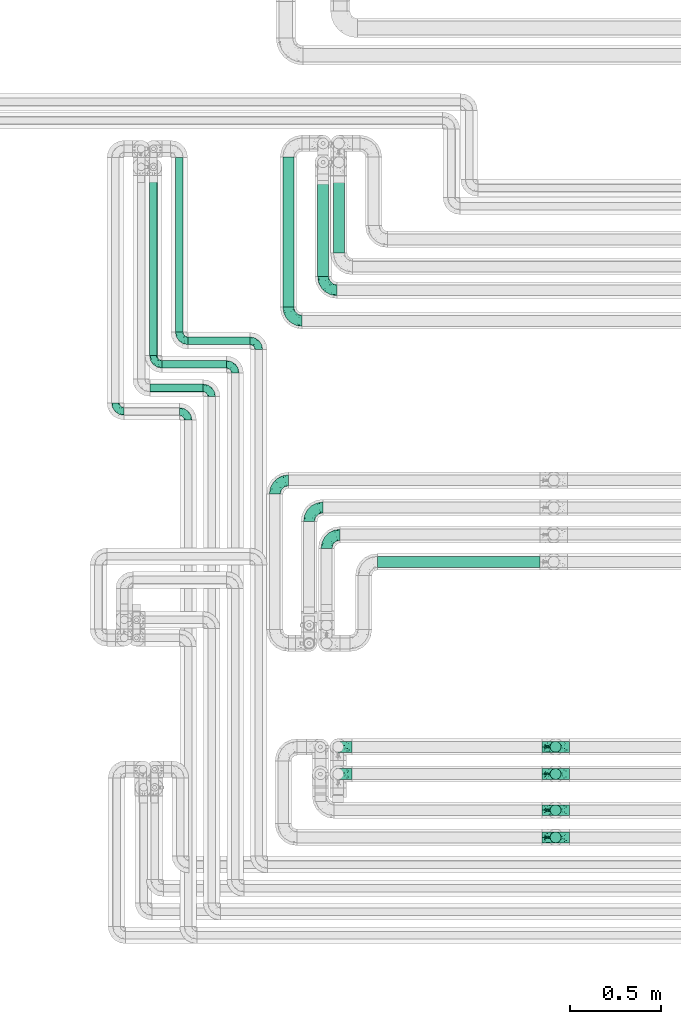
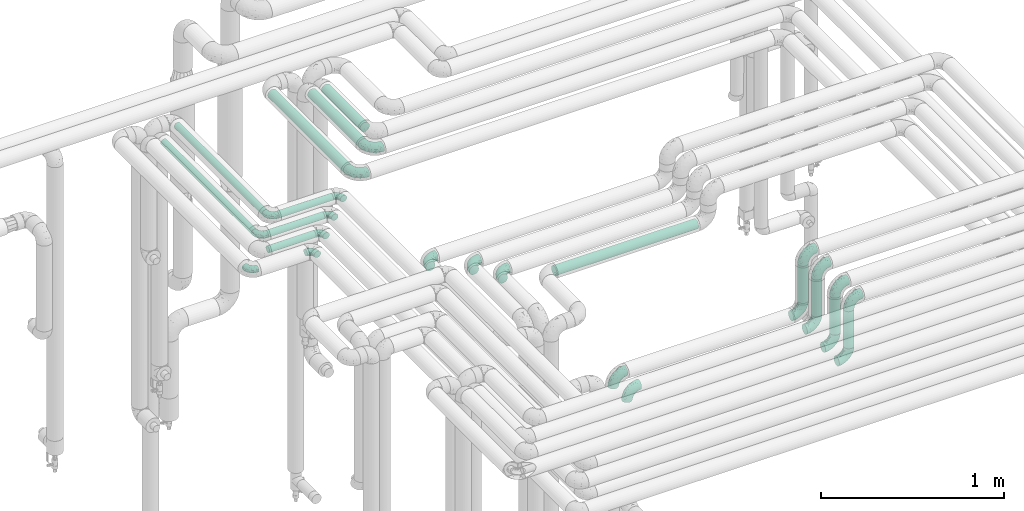
# One storey, part 633 of 824: 22 flow fittings, 13 flow segments.
"""IFC2X3 building model written with IfcOpenShell, lengths in millimetres."""

from ifc_helpers import new_model, entity, si_unit, converted_unit, derived_unit, direction, frame, origin, origin_2d_with_axis, place, context, subcontext, project, spatial, circle, extrude, faceted_brep, source, transform, mapped, material, type_object, type_shapes, element, save


model = new_model("IFC2X3")

# Units and contexts
model_context = context("Model", 3, precision=0.01, world=origin(), true_north=direction((6.12303176911189e-17, 1.0)))
body_context = subcontext(model_context, "Body", "Model", "MODEL_VIEW")
ifc_project = project(units=[si_unit("LENGTHUNIT", "METRE", prefix="MILLI"), si_unit("AREAUNIT", "SQUARE_METRE"), si_unit("VOLUMEUNIT", "CUBIC_METRE"), converted_unit("PLANEANGLEUNIT", "DEGREE", entity("IfcRatioMeasure", 0.0174532925199433), si_unit("PLANEANGLEUNIT", "RADIAN"), dimensions=[0, 0, 0, 0, 0, 0, 0]), si_unit("MASSUNIT", "GRAM", prefix="KILO"), derived_unit("MASSDENSITYUNIT", [(si_unit("MASSUNIT", "GRAM", prefix="KILO"), 1), (si_unit("LENGTHUNIT", "METRE"), -3)]), derived_unit("MOMENTOFINERTIAUNIT", [(si_unit("LENGTHUNIT", "METRE"), 4)]), si_unit("TIMEUNIT", "SECOND"), si_unit("FREQUENCYUNIT", "HERTZ"), si_unit("THERMODYNAMICTEMPERATUREUNIT", "DEGREE_CELSIUS"), derived_unit("THERMALTRANSMITTANCEUNIT", [(si_unit("MASSUNIT", "GRAM", prefix="KILO"), 1), (si_unit("THERMODYNAMICTEMPERATUREUNIT", "KELVIN"), -1), (si_unit("TIMEUNIT", "SECOND"), -3)]), derived_unit("VOLUMETRICFLOWRATEUNIT", [(si_unit("LENGTHUNIT", "METRE"), 3), (si_unit("TIMEUNIT", "SECOND"), -1)]), derived_unit("MASSFLOWRATEUNIT", [(si_unit("MASSUNIT", "GRAM", prefix="KILO"), 1), (si_unit("TIMEUNIT", "SECOND"), -1)]), derived_unit("ROTATIONALFREQUENCYUNIT", [(si_unit("TIMEUNIT", "SECOND"), -1)]), si_unit("ELECTRICCURRENTUNIT", "AMPERE"), si_unit("ELECTRICVOLTAGEUNIT", "VOLT"), si_unit("POWERUNIT", "WATT"), si_unit("FORCEUNIT", "NEWTON", prefix="KILO"), si_unit("ILLUMINANCEUNIT", "LUX"), si_unit("LUMINOUSFLUXUNIT", "LUMEN"), si_unit("LUMINOUSINTENSITYUNIT", "CANDELA"), derived_unit("USERDEFINED", [(si_unit("MASSUNIT", "GRAM", prefix="KILO"), -1), (si_unit("LENGTHUNIT", "METRE"), -2), (si_unit("TIMEUNIT", "SECOND"), 3), (si_unit("LUMINOUSFLUXUNIT", "LUMEN"), 1)]), derived_unit("LINEARVELOCITYUNIT", [(si_unit("LENGTHUNIT", "METRE"), 1), (si_unit("TIMEUNIT", "SECOND"), -1)]), si_unit("PRESSUREUNIT", "PASCAL"), derived_unit("USERDEFINED", [(si_unit("LENGTHUNIT", "METRE"), -2), (si_unit("MASSUNIT", "GRAM", prefix="KILO"), 1), (si_unit("TIMEUNIT", "SECOND"), -2)]), derived_unit("LINEARFORCEUNIT", [(si_unit("MASSUNIT", "GRAM", prefix="KILO"), 1), (si_unit("LENGTHUNIT", "METRE"), 1), (si_unit("TIMEUNIT", "SECOND"), -2), (si_unit("LENGTHUNIT", "METRE"), -1)]), derived_unit("PLANARFORCEUNIT", [(si_unit("MASSUNIT", "GRAM", prefix="KILO"), 1), (si_unit("LENGTHUNIT", "METRE"), 1), (si_unit("TIMEUNIT", "SECOND"), -2), (si_unit("LENGTHUNIT", "METRE"), -2)])], contexts=[model_context])

# Site, building, storey
site_placement = place(None, origin())
site = spatial("IfcSite", under=ifc_project, at=site_placement, CompositionType="ELEMENT")
building_placement = place(site_placement, origin())
building = spatial("IfcBuilding", under=site, at=building_placement, CompositionType="ELEMENT")
storey_placement = place(building_placement, frame((0.0, 0.0, 28200.0)))
storey = spatial("IfcBuildingStorey", under=building, at=storey_placement, CompositionType="ELEMENT", Elevation=28200.0)

# Flow segments
pipe_segment_type = type_object("IfcPipeSegmentType", PredefinedType="NOTDEFINED")
flow_segment_1_placement = place(storey_placement, frame((30915.6, 17358.46, 2977.25)))
element("IfcFlowSegment", 1, at=flow_segment_1_placement, inside=storey, type_object=pipe_segment_type, context=body_context, shape_type="SweptSolid", body=[
    extrude(circle(Radius=21.15, at=origin_2d_with_axis()), frame((0.0, 22.75, 22.75), z_axis=(1.0, 0.0, 0.0), x_axis=(0.0, -1.0, 0.0)), (0.0, 0.0, 1.0), 342.918088784113),
])
flow_segment_2_placement = place(storey_placement, frame((31438.07, 17567.2, 2968.4)))
element("IfcFlowSegment", 2, at=flow_segment_2_placement, inside=storey, type_object=pipe_segment_type, context=body_context, shape_type="SweptSolid", body=[
    extrude(circle(Radius=30.0, at=origin_2d_with_axis()), frame((31.6, 0.0, 31.6), z_axis=(0.0, 1.0, 0.0), x_axis=(1.0, 0.0, 0.0)), (0.0, 0.0, 1.0), 828.00000018509),
])
flow_segment_3_placement = place(storey_placement, frame((30773.07, 17228.46, 2977.25)))
element("IfcFlowSegment", 3, at=flow_segment_3_placement, inside=storey, type_object=pipe_segment_type, context=body_context, shape_type="SweptSolid", body=[
    extrude(circle(Radius=21.15, at=origin_2d_with_axis()), frame((0.0, 22.75, 22.75), z_axis=(1.0, 0.0, 0.0), x_axis=(0.0, -1.0, 0.0)), (0.0, 0.0, 1.0), 355.449929999979),
])
flow_segment_4_placement = place(storey_placement, frame((30705.05, 17098.46, 2977.25)))
element("IfcFlowSegment", 4, at=flow_segment_4_placement, inside=storey, type_object=pipe_segment_type, context=body_context, shape_type="SweptSolid", body=[
    extrude(circle(Radius=21.15, at=origin_2d_with_axis()), frame((0.0, 22.75, 22.75), z_axis=(1.0, 0.0, 0.0), x_axis=(0.0, -1.0, 0.0)), (0.0, 0.0, 1.0), 293.47319999997),
])
flow_segment_5_placement = place(storey_placement, frame((30844.86, 17429.2, 2977.25)))
element("IfcFlowSegment", 5, at=flow_segment_5_placement, inside=storey, type_object=pipe_segment_type, context=body_context, shape_type="SweptSolid", body=[
    extrude(circle(Radius=21.15, at=origin_2d_with_axis()), frame((22.75, 0.0, 22.75), z_axis=(0.0, 1.0, 0.0), x_axis=(1.0, 0.0, 0.0)), (0.0, 0.0, 1.0), 963.999999953802),
])
flow_segment_6_placement = place(storey_placement, frame((30702.33, 17299.2, 2977.25)))
element("IfcFlowSegment", 6, at=flow_segment_6_placement, inside=storey, type_object=pipe_segment_type, context=body_context, shape_type="SweptSolid", body=[
    extrude(circle(Radius=21.15, at=origin_2d_with_axis()), frame((22.75, 0.0, 22.75), z_axis=(0.0, 1.0, 0.0), x_axis=(-1.0, 0.0, 0.0)), (0.0, 0.0, 1.0), 993.999999999995),
])
flow_segment_7_placement = place(storey_placement, frame((31630.07, 17736.2, 2968.4)))
element("IfcFlowSegment", 7, at=flow_segment_7_placement, inside=storey, type_object=pipe_segment_type, context=body_context, shape_type="SweptSolid", body=[
    extrude(circle(Radius=30.0, at=origin_2d_with_axis()), frame((31.6, 0.0, 31.6), z_axis=(0.0, 1.0, 0.0), x_axis=(1.0, 0.0, 0.0)), (0.0, 0.0, 1.0), 554.746270361103),
])
flow_segment_8_placement = place(storey_placement, frame((31717.07, 17867.2, 2968.4)))
element("IfcFlowSegment", 8, at=flow_segment_8_placement, inside=storey, type_object=pipe_segment_type, context=body_context, shape_type="SweptSolid", body=[
    extrude(circle(Radius=30.0, at=origin_2d_with_axis()), frame((31.6, 0.0, 31.6), z_axis=(0.0, 1.0, 0.0), x_axis=(1.0, 0.0, 0.0)), (0.0, 0.0, 1.0), 423.74627954619),
])
for number, where in (
    (9, (32913.44, 15108.41, 3076.0)),
    (10, (32913.44, 14958.41, 3076.0)),
    (11, (32913.44, 14758.41, 3076.0)),
):
    element("IfcFlowSegment", number, at=place(storey_placement, frame(where)), inside=storey, type_object=pipe_segment_type, context=body_context, shape_type="SweptSolid", body=[
        extrude(circle(Radius=30.0, at=origin_2d_with_axis()), frame((31.6, 31.6, 0.0)), (0.0, 0.0, 1.0), 248.000000000013),
    ])
flow_segment_9_placement = place(storey_placement, frame((32913.44, 14608.41, 3076.0)))
element("IfcFlowSegment", 12, at=flow_segment_9_placement, inside=storey, type_object=pipe_segment_type, context=body_context, shape_type="SweptSolid", body=[
    extrude(circle(Radius=30.0, at=origin_2d_with_axis()), frame((31.6, 31.6, 0.0)), (0.0, 0.0, 1.0), 248.000000000022),
])
flow_segment_10_placement = place(storey_placement, frame((31961.25, 16129.61, 2968.4)))
element("IfcFlowSegment", 13, at=flow_segment_10_placement, inside=storey, type_object=pipe_segment_type, context=body_context, shape_type="SweptSolid", body=[
    extrude(circle(Radius=30.0, at=origin_2d_with_axis()), frame((0.0, 31.6, 31.6), z_axis=(1.0, 0.0, 0.0), x_axis=(0.0, 1.0, 0.0)), (0.0, 0.0, 1.0), 897.780008999999),
])

# Flow fittings
ifc_material = material()
pipe_fitting_type_1 = type_object("IfcPipeFittingType", PredefinedType="NOTDEFINED", material=ifc_material)
shared_shape_1 = source(origin(), body_context, "Body", "Brep", [
    faceted_brep([(-48.0, 10.6, -18.36), (-48.0, 5.49, -20.48), (-48.0, 0.0, -21.2), (-48.0, -5.49, -20.48), (-48.0, -10.6, -18.36), (-48.0, -14.99, -14.99), (-48.0, -18.36, -10.6), (-48.0, -20.48, -5.49), (-48.0, -21.2, 0.0), (-48.0, -20.48, 5.49), (-48.0, -18.36, 10.6), (-48.0, -14.99, 14.99), (-48.0, -10.6, 18.36), (-48.0, -5.49, 20.48), (-48.0, 0.0, 21.2), (-48.0, 5.49, 20.48), (-48.0, 10.6, 18.36), (-48.0, 14.99, 14.99), (-48.0, 18.36, 10.6), (-48.0, 20.48, 5.49), (-48.0, 21.2, 0.0), (-48.0, 20.48, -5.49), (-48.0, 18.36, -10.6), (-48.0, 14.99, -14.99), (0.0, 48.0, -21.2), (-5.49, 48.0, -20.48), (-10.6, 48.0, -18.36), (-14.99, 48.0, -14.99), (-18.36, 48.0, -10.6), (-20.48, 48.0, -5.49), (-21.2, 48.0, 0.0), (-20.48, 48.0, 5.49), (-18.36, 48.0, 10.6), (-14.99, 48.0, 14.99), (-10.6, 48.0, 18.36), (-5.49, 48.0, 20.48), (0.0, 48.0, 21.2), (5.49, 48.0, 20.48), (10.6, 48.0, 18.36), (14.99, 48.0, 14.99), (18.36, 48.0, 10.6), (20.48, 48.0, 5.49), (21.2, 48.0, 0.0), (20.48, 48.0, -5.49), (18.36, 48.0, -10.6), (14.99, 48.0, -14.99), (10.6, 48.0, -18.36), (5.49, 48.0, -20.48), (-35.25, -16.22, 12.01), (-34.76, -18.57, 0.0), (-20.87, -12.37, 10.9), (-31.49, -11.78, 15.9), (-37.0, -2.58, 20.86), (-33.89, 3.62, 21.15), (-31.81, -18.14, 6.76), (-5.78, 5.78, 17.67), (-19.42, -4.1, 17.86), (-9.6, -3.39, 13.73), (-35.44, -7.73, 19.13), (11.78, 31.49, 15.9), (-5.93, -5.46, 6.95), (-18.45, -13.78, 5.46), (-10.29, -8.43, 0.0), (-24.6, 0.55, 20.62), (-37.28, 17.94, 13.81), (-33.38, 22.85, 9.59), (-41.46, 20.06, 8.75), (-29.51, 20.45, 15.16), (-15.04, 10.79, 21.13), (-7.08, 16.98, 20.93), (-8.39, 23.51, 21.15), (-40.86, 13.03, 17.26), (-8.05, 41.26, 19.83), (-3.21, 35.97, 21.14), (8.53, 19.66, 14.74), (4.1, 19.42, 17.86), (-37.72, 22.66, 4.78), (-37.07, 8.58, 19.98), (-13.0, 5.43, 19.97), (-3.78, 13.93, 19.7), (3.02, 8.69, 13.43), (-2.27, -0.05, 10.65), (6.22, 6.99, 7.09), (-22.25, 34.6, 9.45), (18.14, 31.81, 6.76), (16.22, 35.25, 12.01), (12.37, 20.87, 10.9), (7.73, 35.44, 19.13), (-21.52, -15.93, 0.0), (2.58, 37.0, 20.86), (18.57, 34.76, 0.0), (13.78, 18.45, 5.46), (15.93, 21.52, 0.0), (-20.03, -8.54, 14.9), (-28.6, 28.6, 5.16), (-24.79, 34.6, 0.0), (-34.6, 24.79, 0.0), (-22.81, 37.41, 4.68), (-23.36, 26.33, 14.79), (-13.68, 37.05, 17.49), (-17.72, 38.12, 13.73), (-26.25, 27.3, 11.24), (-9.71, 32.34, 20.14), (-17.26, 25.6, 18.71), (-26.33, 9.99, 20.77), (-24.06, 6.05, 21.2), (-25.02, 15.46, 19.56), (-24.3, 20.72, 17.57), (-31.95, 15.23, 17.8), (-13.53, 24.7, 20.21), (-17.6, 17.6, 20.6), (-0.55, 24.6, 20.62), (-11.41, -7.48, 10.43), (0.93, -0.93, 0.0), (8.43, 10.29, 0.0), (-11.41, -7.48, -10.43), (-20.1, -8.84, -14.66), (-9.6, -3.39, -13.73), (7.73, 35.44, -19.13), (4.1, 19.42, -17.86), (-0.55, 24.6, -20.62), (-38.12, 17.72, -13.73), (-37.05, 13.68, -17.49), (-32.34, 9.71, -20.14), (-41.26, 8.05, -19.83), (-37.41, 22.81, -4.68), (-23.51, 8.39, -21.15), (-35.97, 3.21, -21.14), (-28.6, 28.6, -5.16), (-31.81, -18.14, -6.76), (-18.45, -13.78, -5.46), (-25.6, 17.26, -18.71), (-19.42, -4.1, -17.86), (-17.94, 37.28, -13.81), (-22.85, 33.38, -9.59), (-20.06, 41.46, -8.75), (-31.49, -11.78, -15.9), (-35.25, -16.22, -12.01), (8.53, 19.66, -14.74), (11.78, 31.49, -15.9), (-9.99, 26.33, -20.77), (-6.05, 24.06, -21.2), (-10.79, 15.04, -21.13), (-37.0, -2.58, -20.86), (-16.98, 7.08, -20.93), (-5.43, 13.0, -19.97), (-13.93, 3.78, -19.7), (-20.87, -12.37, -10.9), (-26.33, 23.36, -14.79), (-22.66, 37.72, -4.78), (13.78, 18.45, -5.46), (18.14, 31.81, -6.76), (-15.46, 25.02, -19.56), (-20.72, 24.3, -17.57), (16.22, 35.25, -12.01), (-13.03, 40.86, -17.26), (-8.58, 37.07, -19.98), (2.58, 37.0, -20.86), (-3.62, 33.89, -21.15), (-34.6, 22.25, -9.45), (6.22, 6.99, -7.09), (-20.45, 29.51, -15.16), (-35.44, -7.73, -19.13), (12.37, 20.87, -10.9), (-27.3, 26.25, -11.24), (-15.23, 31.95, -17.8), (-24.7, 13.53, -20.21), (-24.6, 0.55, -20.62), (-5.78, 5.78, -17.67), (-17.6, 17.6, -20.6), (3.02, 8.69, -13.43), (-5.93, -5.46, -6.95), (-2.27, -0.05, -10.65)], [[[0, 1, 2, 3, 4, 5, 6, 7, 8, 9, 10, 11, 12, 13, 14, 15, 16, 17, 18, 19, 20, 21, 22, 23]], [[24, 25, 26, 27, 28, 29, 30, 31, 32, 33, 34, 35, 36, 37, 38, 39, 40, 41, 42, 43, 44, 45, 46, 47]], [[10, 48, 11]], [[9, 8, 49]], [[48, 50, 51]], [[14, 52, 53]], [[10, 54, 48]], [[9, 54, 10]], [[55, 56, 57]], [[51, 12, 11]], [[51, 58, 12]], [[59, 39, 38]], [[60, 61, 62]], [[58, 56, 63]], [[64, 65, 66]], [[67, 65, 64]], [[68, 69, 70]], [[16, 71, 17]], [[13, 52, 14]], [[35, 72, 73]], [[14, 53, 15]], [[17, 64, 18]], [[74, 59, 75]], [[20, 19, 76]], [[66, 19, 18]], [[77, 15, 53]], [[15, 77, 16]], [[69, 78, 79]], [[80, 81, 82]], [[32, 31, 83]], [[84, 85, 86]], [[59, 87, 75]], [[61, 54, 88]], [[36, 89, 37]], [[84, 41, 40]], [[36, 35, 73]], [[90, 41, 84]], [[40, 39, 85]], [[12, 58, 13]], [[85, 84, 40]], [[91, 84, 86]], [[84, 92, 90]], [[87, 38, 37]], [[93, 56, 51]], [[65, 94, 76]], [[94, 95, 96]], [[84, 91, 92]], [[95, 97, 30]], [[98, 99, 100]], [[76, 94, 96]], [[101, 98, 83]], [[100, 99, 33]], [[102, 70, 73]], [[103, 102, 99]], [[94, 97, 95]], [[72, 99, 102]], [[72, 35, 34]], [[34, 33, 99]], [[9, 49, 54]], [[87, 59, 38]], [[104, 105, 68]], [[106, 103, 107]], [[106, 77, 104]], [[71, 64, 17]], [[108, 107, 67]], [[33, 32, 100]], [[109, 103, 110]], [[102, 109, 70]], [[89, 73, 111]], [[50, 48, 54]], [[51, 11, 48]], [[56, 58, 51]], [[88, 54, 49]], [[52, 58, 63]], [[50, 112, 93]], [[56, 55, 78]], [[39, 59, 85]], [[86, 85, 59]], [[89, 87, 37]], [[42, 41, 90]], [[111, 79, 75]], [[111, 75, 87]], [[75, 55, 80]], [[104, 77, 53]], [[71, 77, 108]], [[32, 83, 100]], [[98, 100, 83]], [[99, 98, 103]], [[106, 107, 108]], [[68, 70, 110]], [[111, 73, 70]], [[68, 110, 104]], [[68, 63, 78]], [[57, 93, 112]], [[80, 55, 57]], [[61, 50, 54]], [[80, 82, 86]], [[81, 57, 112]], [[74, 86, 59]], [[60, 113, 82]], [[82, 114, 91]], [[101, 94, 65]], [[97, 94, 83]], [[73, 89, 36]], [[87, 89, 111]], [[58, 52, 13]], [[53, 52, 63]], [[104, 53, 105]], [[106, 104, 110]], [[20, 76, 96]], [[76, 19, 66]], [[103, 106, 110]], [[77, 106, 108]], [[103, 98, 107]], [[67, 107, 98]], [[67, 98, 101]], [[108, 67, 64]], [[53, 63, 105]], [[63, 68, 105]], [[83, 31, 97]], [[30, 97, 31]], [[62, 113, 60]], [[112, 61, 60]], [[61, 88, 62]], [[86, 82, 91]], [[56, 78, 63]], [[114, 82, 113]], [[114, 92, 91]], [[79, 78, 55]], [[75, 79, 55]], [[69, 79, 111]], [[70, 69, 111]], [[78, 69, 68]], [[77, 71, 16]], [[64, 71, 108]], [[64, 66, 18]], [[76, 66, 65]], [[99, 72, 34]], [[73, 72, 102]], [[94, 101, 83]], [[67, 101, 65]], [[75, 80, 74]], [[80, 86, 74]], [[70, 109, 110]], [[102, 103, 109]], [[50, 93, 51]], [[57, 56, 93]], [[61, 112, 50]], [[81, 112, 60]], [[82, 81, 60]], [[80, 57, 81]], [[115, 116, 117]], [[118, 119, 120]], [[121, 122, 23]], [[123, 124, 122]], [[96, 125, 20]], [[123, 126, 127]], [[128, 96, 95]], [[129, 130, 88]], [[123, 122, 131]], [[116, 132, 117]], [[133, 134, 135]], [[0, 124, 1]], [[5, 136, 137]], [[138, 119, 139]], [[129, 88, 49]], [[140, 141, 142]], [[6, 5, 137]], [[46, 118, 47]], [[143, 3, 2]], [[144, 145, 146]], [[6, 129, 7]], [[129, 137, 147]], [[127, 2, 1]], [[148, 122, 121]], [[128, 125, 96]], [[134, 128, 149]], [[95, 149, 128]], [[150, 151, 92]], [[30, 29, 149]], [[152, 131, 153]], [[27, 133, 28]], [[154, 45, 44]], [[136, 5, 4]], [[27, 26, 155]], [[156, 26, 25]], [[24, 157, 158]], [[24, 47, 157]], [[22, 21, 159]], [[160, 150, 114]], [[134, 133, 161]], [[142, 144, 126]], [[46, 139, 118]], [[162, 136, 4]], [[156, 25, 158]], [[1, 124, 127]], [[115, 147, 116]], [[45, 154, 139]], [[139, 46, 45]], [[154, 163, 139]], [[162, 4, 3]], [[42, 90, 43]], [[130, 129, 147]], [[49, 7, 129]], [[43, 151, 44]], [[0, 23, 122]], [[24, 158, 25]], [[136, 162, 132]], [[135, 29, 28]], [[43, 90, 151]], [[164, 148, 159]], [[152, 156, 140]], [[155, 133, 27]], [[165, 153, 161]], [[23, 22, 121]], [[123, 131, 166]], [[123, 166, 126]], [[143, 127, 167]], [[147, 137, 136]], [[8, 7, 49]], [[129, 6, 137]], [[143, 162, 3]], [[167, 146, 132]], [[167, 132, 162]], [[132, 168, 117]], [[44, 151, 154]], [[92, 151, 90]], [[163, 154, 151]], [[119, 118, 139]], [[157, 118, 120]], [[138, 139, 163]], [[119, 168, 145]], [[140, 156, 158]], [[155, 156, 165]], [[22, 159, 121]], [[148, 121, 159]], [[122, 148, 131]], [[152, 153, 165]], [[142, 126, 169]], [[167, 127, 126]], [[142, 169, 140]], [[142, 120, 145]], [[168, 170, 117]], [[160, 171, 172]], [[115, 172, 171]], [[171, 62, 130]], [[119, 170, 168]], [[170, 163, 160]], [[150, 163, 151]], [[113, 171, 160]], [[164, 128, 134]], [[125, 128, 159]], [[127, 143, 2]], [[162, 143, 167]], [[118, 157, 47]], [[158, 157, 120]], [[140, 158, 141]], [[152, 140, 169]], [[30, 149, 95]], [[149, 29, 135]], [[131, 152, 169]], [[156, 152, 165]], [[131, 148, 153]], [[161, 153, 148]], [[161, 148, 164]], [[165, 161, 133]], [[158, 120, 141]], [[120, 142, 141]], [[159, 21, 125]], [[20, 125, 21]], [[115, 130, 147]], [[114, 113, 160]], [[62, 171, 113]], [[62, 88, 130]], [[160, 163, 150]], [[150, 92, 114]], [[119, 145, 120]], [[146, 145, 168]], [[132, 146, 168]], [[144, 146, 167]], [[126, 144, 167]], [[145, 144, 142]], [[156, 155, 26]], [[133, 155, 165]], [[133, 135, 28]], [[149, 135, 134]], [[122, 124, 0]], [[127, 124, 123]], [[128, 164, 159]], [[161, 164, 134]], [[163, 170, 138]], [[170, 119, 138]], [[131, 169, 166]], [[126, 166, 169]], [[147, 136, 116]], [[132, 116, 136]], [[172, 115, 117]], [[130, 115, 171]], [[117, 170, 172]], [[160, 172, 170]]]),
])
type_shapes(pipe_fitting_type_1, [shared_shape_1])
for number, where, z_axis, x_axis in (
    (14, (30867.6, 17381.2, 3000.0), (0.0, 0.0, 1.0), (0.0, -1.0, 0.0)),
    (15, (31176.52, 17251.2, 3000.0), (0.0, 0.0, 1.0), (0.0, 1.0, 0.0)),
    (16, (31046.52, 17121.2, 3000.0), (0.0, 0.0, 1.0), (0.0, 1.0, 0.0)),
    (17, (30515.05, 16991.2, 3000.0), (0.0, 0.0, 1.0), (0.0, -1.0, 0.0)),
    (18, (30916.52, 16991.2, 3000.0), (0.0, 0.0, 1.0), (0.0, 1.0, 0.0)),
    (19, (30725.07, 17251.2, 3000.0), (0.0, 0.0, 1.0), (0.0, -1.0, 0.0)),
    (20, (31306.52, 17381.2, 3000.0), (0.0, 0.0, 1.0), (0.0, 1.0, 0.0)),
):
    element("IfcFlowFitting", number, at=place(storey_placement, frame(where, z_axis=z_axis, x_axis=x_axis)), inside=storey, type_object=pipe_fitting_type_1, material=ifc_material, context=body_context, shape_type="MappedRepresentation", body=[
        mapped(shared_shape_1, transform((0.0, 0.0, 0.0), scale=1.0)),
    ])
pipe_fitting_type_2 = type_object("IfcPipeFittingType", PredefinedType="NOTDEFINED", material=ifc_material)
shared_shape_2 = source(origin(), body_context, "Body", "Brep", [
    faceted_brep([(-76.0, 15.07, -26.11), (-76.0, 7.8, -29.12), (-76.0, 0.0, -30.15), (-76.0, -7.8, -29.12), (-76.0, -15.08, -26.11), (-76.0, -21.32, -21.32), (-76.0, -26.11, -15.08), (-76.0, -29.12, -7.8), (-76.0, -30.15, 0.0), (-76.0, -29.12, 7.8), (-76.0, -26.11, 15.07), (-76.0, -21.32, 21.32), (-76.0, -15.08, 26.11), (-76.0, -7.8, 29.12), (-76.0, 0.0, 30.15), (-76.0, 7.8, 29.12), (-76.0, 15.07, 26.11), (-76.0, 21.32, 21.32), (-76.0, 26.11, 15.07), (-76.0, 29.12, 7.8), (-76.0, 30.15, 0.0), (-76.0, 29.12, -7.8), (-76.0, 26.11, -15.08), (-76.0, 21.32, -21.32), (0.0, 76.0, -30.15), (-7.8, 76.0, -29.12), (-15.07, 76.0, -26.11), (-21.32, 76.0, -21.32), (-26.11, 76.0, -15.08), (-29.12, 76.0, -7.8), (-30.15, 76.0, 0.0), (-29.12, 76.0, 7.8), (-26.11, 76.0, 15.07), (-21.32, 76.0, 21.32), (-15.07, 76.0, 26.11), (-7.8, 76.0, 29.12), (0.0, 76.0, 30.15), (7.8, 76.0, 29.12), (15.08, 76.0, 26.11), (21.32, 76.0, 21.32), (26.11, 76.0, 15.07), (29.12, 76.0, 7.8), (30.15, 76.0, 0.0), (29.12, 76.0, -7.8), (26.11, 76.0, -15.08), (21.32, 76.0, -21.32), (15.08, 76.0, -26.11), (7.8, 76.0, -29.12), (10.79, 31.43, 21.07), (4.32, 31.7, 25.72), (1.65, 15.19, 19.92), (-61.17, -27.8, 0.0), (-51.1, -25.49, 9.84), (-56.14, -10.61, 27.27), (-31.7, -4.32, 25.72), (-39.75, 1.72, 29.41), (-43.2, -24.95, 0.0), (-1.86, 1.86, 0.0), (4.49, 7.65, 5.78), (-7.82, -4.61, 5.83), (-56.21, -22.79, 17.21), (-58.98, -3.38, 29.7), (-53.96, 5.6, 30.07), (-10.86, 10.86, 25.48), (-17.2, -2.6, 20.44), (-49.15, -16.01, 22.7), (-22.18, -14.24, 7.99), (-28.4, -17.42, 0.0), (-13.61, -9.88, 0.0), (-39.0, 23.48, 27.76), (-58.76, 12.54, 28.36), (-41.61, 15.41, 29.48), (16.01, 49.15, 22.7), (-58.55, 25.93, 19.53), (-51.53, 33.5, 13.51), (-64.92, 28.76, 12.4), (-7.48, 23.14, 28.25), (-1.72, 39.75, 29.41), (-12.04, 27.88, 29.88), (-63.91, 18.81, 24.52), (-11.63, 65.16, 28.18), (-4.97, 57.02, 30.05), (9.88, 13.61, 0.0), (-62.5, 31.74, 5.02), (-45.17, 30.98, 21.2), (-21.78, 9.76, 28.58), (10.61, 56.14, 27.27), (-32.09, 54.42, 13.26), (22.79, 56.21, 17.21), (15.38, 31.17, 15.63), (25.49, 51.1, 9.84), (21.84, 36.35, 5.92), (24.95, 43.2, 0.0), (3.38, 58.98, 29.7), (-31.17, -15.38, 15.63), (-39.39, 41.78, 15.45), (-34.56, 41.13, 20.79), (-39.81, -23.25, 5.49), (27.8, 61.17, 0.0), (-31.74, 62.5, 5.02), (-53.07, 36.29, 0.0), (-42.95, 42.95, 7.29), (-36.29, 53.07, 0.0), (-19.83, 58.51, 24.79), (-25.48, 60.2, 19.41), (-14.53, 50.96, 28.57), (-13.31, 37.09, 30.07), (-26.16, 40.06, 26.4), (-32.43, -10.35, 21.9), (17.42, 28.4, 0.0), (14.24, 22.18, 7.99), (-38.67, 9.72, 30.15), (-24.66, 17.36, 30.09), (-37.08, 31.49, 24.99), (-49.27, 22.83, 25.24), (-20.8, 38.81, 28.63), (-27.58, 27.58, 29.2), (-36.07, -20.23, 10.71), (-15.19, -6.16, 14.9), (6.6, 15.4, 14.49), (-2.51, 2.51, 11.35), (-65.16, 11.63, -28.18), (-49.15, -16.01, -22.7), (-57.02, 4.97, -30.05), (-25.93, 58.55, -19.53), (-33.5, 51.53, -13.51), (-28.76, 64.92, -12.4), (-60.2, 25.48, -19.41), (-58.51, 19.83, -24.79), (4.61, 7.82, -5.83), (-7.65, -4.49, -5.78), (-2.51, 2.51, -11.35), (-62.5, 31.74, -5.02), (-50.96, 14.53, -28.57), (-37.09, 13.31, -30.07), (-42.95, 42.95, -7.29), (25.49, 51.1, -9.84), (22.79, 56.21, -17.21), (-40.06, 26.16, -26.4), (3.38, 58.98, -29.7), (-5.6, 53.96, -30.07), (-27.88, 12.04, -29.88), (-9.76, 21.78, -28.58), (-23.14, 7.48, -28.25), (-51.1, -25.49, -9.84), (15.38, 31.17, -15.63), (16.01, 49.15, -22.7), (-23.48, 39.0, -27.76), (-12.54, 58.76, -28.36), (-15.41, 41.61, -29.48), (-56.21, -22.79, -17.21), (-9.72, 38.67, -30.15), (-17.36, 24.66, -30.09), (-22.18, -14.24, -7.99), (-41.13, 34.56, -20.79), (-31.74, 62.5, -5.02), (-58.98, -3.38, -29.7), (-31.17, -15.38, -15.63), (-56.14, -10.61, -27.27), (14.24, 22.18, -7.99), (23.25, 39.81, -5.49), (-31.49, 37.08, -24.99), (-15.19, -6.16, -14.9), (1.65, 15.19, -19.92), (-18.81, 63.91, -24.52), (-32.59, -11.62, -20.84), (-31.7, -4.32, -25.72), (-17.2, -2.6, -20.44), (-39.75, 1.72, -29.41), (-54.42, 32.09, -13.26), (-30.98, 45.17, -21.2), (10.61, 56.14, -27.27), (10.23, 31.31, -21.52), (4.32, 31.7, -25.72), (-41.78, 39.39, -15.45), (-1.72, 39.75, -29.41), (-36.35, -21.84, -5.92), (-22.83, 49.27, -25.24), (-38.81, 20.8, -28.63), (-27.58, 27.58, -29.2), (-10.86, 10.86, -25.48), (20.23, 36.07, -10.71), (6.6, 15.4, -14.49)], [[[0, 1, 2, 3, 4, 5, 6, 7, 8, 9, 10, 11, 12, 13, 14, 15, 16, 17, 18, 19, 20, 21, 22, 23]], [[24, 25, 26, 27, 28, 29, 30, 31, 32, 33, 34, 35, 36, 37, 38, 39, 40, 41, 42, 43, 44, 45, 46, 47]], [[48, 49, 50]], [[51, 52, 9]], [[53, 54, 55]], [[9, 52, 10]], [[56, 52, 51]], [[57, 58, 59]], [[11, 10, 60]], [[14, 61, 62]], [[63, 54, 64]], [[65, 12, 11]], [[65, 53, 12]], [[66, 67, 68]], [[69, 70, 71]], [[72, 39, 38]], [[73, 74, 75]], [[15, 70, 16]], [[76, 77, 78]], [[16, 79, 17]], [[13, 61, 14]], [[35, 80, 81]], [[14, 62, 15]], [[17, 73, 18]], [[57, 82, 58]], [[20, 19, 83]], [[75, 19, 18]], [[70, 15, 62]], [[73, 84, 74]], [[78, 85, 76]], [[38, 86, 72]], [[32, 31, 87]], [[88, 89, 90]], [[91, 92, 90]], [[72, 86, 49]], [[36, 93, 37]], [[75, 83, 19]], [[36, 35, 81]], [[60, 94, 65]], [[40, 90, 41]], [[95, 96, 87]], [[88, 90, 40]], [[66, 97, 67]], [[90, 98, 41]], [[40, 39, 88]], [[99, 31, 30]], [[20, 83, 100]], [[101, 102, 100]], [[52, 60, 10]], [[102, 99, 30]], [[96, 103, 104]], [[83, 101, 100]], [[12, 53, 13]], [[104, 103, 33]], [[105, 106, 81]], [[107, 105, 103]], [[64, 54, 108]], [[80, 103, 105]], [[80, 35, 34]], [[34, 33, 103]], [[86, 38, 37]], [[109, 110, 82]], [[71, 111, 112]], [[69, 107, 113]], [[79, 73, 17]], [[114, 113, 84]], [[33, 32, 104]], [[115, 107, 116]], [[105, 115, 106]], [[93, 81, 77]], [[54, 53, 65]], [[61, 53, 55]], [[108, 94, 64]], [[54, 63, 85]], [[93, 86, 37]], [[77, 76, 49]], [[77, 49, 86]], [[49, 63, 50]], [[60, 52, 117]], [[65, 11, 60]], [[39, 72, 88]], [[89, 88, 72]], [[71, 70, 62]], [[79, 70, 114]], [[103, 96, 107]], [[69, 113, 114]], [[112, 106, 116]], [[77, 81, 106]], [[112, 116, 71]], [[112, 55, 85]], [[64, 50, 63]], [[57, 59, 68]], [[32, 87, 104]], [[96, 104, 87]], [[94, 118, 64]], [[50, 119, 89]], [[50, 64, 118]], [[50, 89, 48]], [[81, 93, 36]], [[86, 93, 77]], [[53, 61, 13]], [[62, 61, 55]], [[71, 62, 111]], [[69, 71, 116]], [[95, 101, 74]], [[99, 101, 87]], [[118, 66, 59]], [[117, 97, 66]], [[117, 66, 94]], [[91, 89, 110]], [[91, 110, 109]], [[110, 89, 119]], [[9, 8, 51]], [[98, 90, 92]], [[98, 42, 41]], [[101, 83, 74]], [[101, 99, 102]], [[87, 31, 99]], [[62, 55, 111]], [[55, 112, 111]], [[107, 69, 116]], [[70, 69, 114]], [[107, 96, 113]], [[84, 113, 96]], [[84, 96, 95]], [[114, 84, 73]], [[70, 79, 16]], [[73, 79, 114]], [[54, 85, 55]], [[76, 85, 63]], [[49, 76, 63]], [[77, 106, 78]], [[106, 112, 78]], [[85, 78, 112]], [[73, 75, 18]], [[83, 75, 74]], [[103, 80, 34]], [[81, 80, 105]], [[101, 95, 87]], [[84, 95, 74]], [[106, 115, 116]], [[105, 107, 115]], [[120, 59, 58]], [[82, 110, 58]], [[119, 58, 110]], [[118, 59, 120]], [[66, 68, 59]], [[54, 65, 108]], [[94, 108, 65]], [[66, 118, 94]], [[50, 118, 120]], [[50, 120, 119]], [[119, 120, 58]], [[89, 72, 48]], [[49, 48, 72]], [[60, 117, 94]], [[117, 52, 97]], [[52, 56, 97]], [[67, 97, 56]], [[92, 91, 109]], [[89, 91, 90]], [[121, 1, 0]], [[122, 5, 4]], [[2, 1, 123]], [[124, 125, 126]], [[127, 128, 23]], [[129, 130, 131]], [[100, 132, 20]], [[133, 134, 123]], [[135, 100, 102]], [[136, 137, 44]], [[133, 128, 138]], [[24, 139, 140]], [[141, 142, 143]], [[121, 128, 133]], [[6, 144, 7]], [[137, 145, 146]], [[144, 51, 7]], [[147, 148, 149]], [[144, 6, 150]], [[149, 151, 152]], [[153, 68, 67]], [[154, 128, 127]], [[30, 155, 102]], [[43, 42, 98]], [[156, 3, 2]], [[157, 144, 150]], [[158, 4, 3]], [[24, 140, 25]], [[155, 135, 102]], [[159, 160, 109]], [[30, 29, 155]], [[147, 138, 161]], [[27, 124, 28]], [[57, 129, 82]], [[162, 163, 131]], [[27, 26, 164]], [[148, 26, 25]], [[165, 166, 167]], [[24, 47, 139]], [[143, 168, 141]], [[22, 21, 169]], [[125, 124, 170]], [[148, 25, 140]], [[46, 146, 171]], [[158, 122, 4]], [[0, 23, 128]], [[1, 121, 123]], [[109, 82, 159]], [[45, 44, 137]], [[146, 46, 45]], [[136, 43, 98]], [[132, 21, 20]], [[136, 98, 92]], [[172, 173, 146]], [[46, 171, 47]], [[43, 136, 44]], [[174, 154, 169]], [[171, 173, 175]], [[6, 5, 150]], [[126, 29, 28]], [[176, 56, 144]], [[122, 158, 166]], [[164, 124, 27]], [[177, 161, 170]], [[23, 22, 127]], [[178, 138, 179]], [[133, 178, 134]], [[156, 123, 168]], [[156, 158, 3]], [[168, 143, 166]], [[168, 166, 158]], [[166, 180, 167]], [[173, 171, 146]], [[139, 171, 175]], [[172, 145, 163]], [[173, 180, 142]], [[5, 122, 150]], [[157, 150, 122]], [[137, 136, 181]], [[146, 45, 137]], [[149, 148, 140]], [[164, 148, 177]], [[128, 154, 138]], [[147, 161, 177]], [[152, 134, 179]], [[168, 123, 134]], [[152, 179, 149]], [[152, 175, 142]], [[57, 130, 129]], [[157, 165, 167]], [[22, 169, 127]], [[154, 127, 169]], [[163, 167, 180]], [[162, 157, 167]], [[173, 163, 180]], [[182, 163, 145]], [[123, 156, 2]], [[158, 156, 168]], [[171, 139, 47]], [[140, 139, 175]], [[149, 140, 151]], [[147, 149, 179]], [[174, 135, 125]], [[132, 135, 169]], [[176, 157, 153]], [[176, 153, 67]], [[153, 157, 162]], [[182, 159, 129]], [[181, 160, 159]], [[181, 159, 145]], [[51, 144, 56]], [[51, 8, 7]], [[135, 132, 100]], [[169, 21, 132]], [[126, 155, 29]], [[135, 155, 125]], [[140, 175, 151]], [[175, 152, 151]], [[138, 147, 179]], [[148, 147, 177]], [[138, 154, 161]], [[170, 161, 154]], [[170, 154, 174]], [[177, 170, 124]], [[148, 164, 26]], [[124, 164, 177]], [[173, 142, 175]], [[143, 142, 180]], [[166, 143, 180]], [[168, 134, 141]], [[134, 152, 141]], [[142, 141, 152]], [[124, 126, 28]], [[155, 126, 125]], [[128, 121, 0]], [[123, 121, 133]], [[135, 174, 169]], [[170, 174, 125]], [[134, 178, 179]], [[133, 138, 178]], [[130, 153, 162]], [[68, 153, 130]], [[57, 68, 130]], [[182, 129, 131]], [[159, 82, 129]], [[157, 122, 165]], [[166, 165, 122]], [[163, 162, 167]], [[162, 131, 130]], [[145, 172, 146]], [[163, 173, 172]], [[159, 182, 145]], [[131, 163, 182]], [[56, 176, 67]], [[157, 176, 144]], [[137, 181, 145]], [[181, 136, 160]], [[136, 92, 160]], [[109, 160, 92]]]),
])
type_shapes(pipe_fitting_type_2, [shared_shape_2])
for number, where, z_axis, x_axis in (
    (21, (31469.66, 17491.2, 3000.0), (0.0, 0.0, 1.0), (0.0, -1.0, 0.0)),
    (22, (31661.66, 17660.2, 3000.0), (0.0, 0.0, 1.0), (0.0, -1.0, 0.0)),
    (23, (32945.03, 15140.0, 3400.0), (0.0, -1.0, 0.0), (-1.0, 0.0, 0.0)),
    (24, (32945.03, 14990.0, 3400.0), (0.0, -1.0, 0.0), (-1.0, 0.0, 0.0)),
    (25, (32945.03, 14790.0, 3400.0), (0.0, -1.0, 0.0), (-1.0, 0.0, 0.0)),
    (26, (32945.03, 14640.0, 3400.0), (0.0, -1.0, 0.0), (-1.0, 0.0, 0.0)),
    (27, (32945.03, 14640.0, 3000.0), (0.0, 1.0, 0.0), (0.0, 0.0, -1.0)),
    (28, (32945.03, 15140.0, 3000.0), (0.0, 1.0, 0.0), (0.0, 0.0, -1.0)),
    (29, (31680.25, 16311.2, 3000.0), (0.0, 0.0, 1.0), (-1.0, 0.0, 0.0)),
    (30, (31584.25, 16461.2, 3000.0), (0.0, 0.0, 1.0), (-1.0, 0.0, 0.0)),
    (31, (31395.03, 16611.2, 3000.0), (0.0, 0.0, 1.0), (-1.0, 0.0, 0.0)),
    (32, (32945.03, 14790.0, 3000.0), (0.0, 1.0, 0.0), (0.0, 0.0, -1.0)),
    (33, (31745.03, 15140.0, 3000.0), (0.0, -1.0, 0.0), (-1.0, 0.0, 0.0)),
    (34, (32945.03, 14990.0, 3000.0), (0.0, 1.0, 0.0), (0.0, 0.0, -1.0)),
    (35, (31745.03, 14990.0, 3000.0), (0.0, 1.0, 0.0), (0.0, 0.0, 1.0)),
):
    element("IfcFlowFitting", number, at=place(storey_placement, frame(where, z_axis=z_axis, x_axis=x_axis)), inside=storey, type_object=pipe_fitting_type_2, material=ifc_material, context=body_context, shape_type="MappedRepresentation", body=[
        mapped(shared_shape_2, transform((0.0, 0.0, 0.0), scale=1.0)),
    ])

save(model, "model.ifc")
